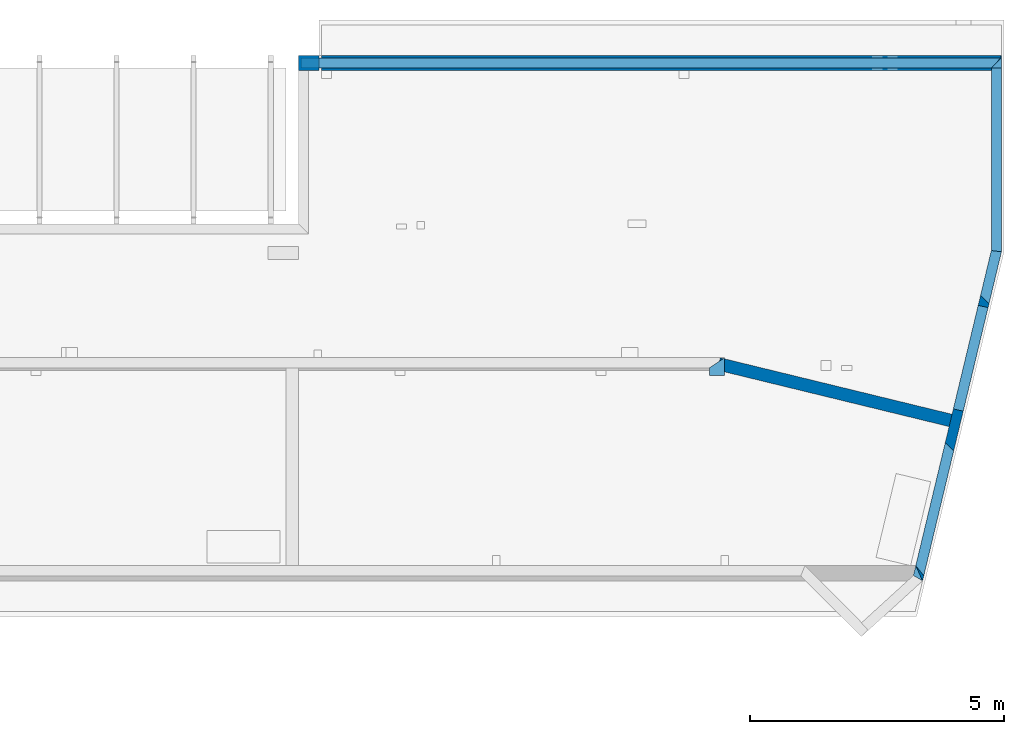
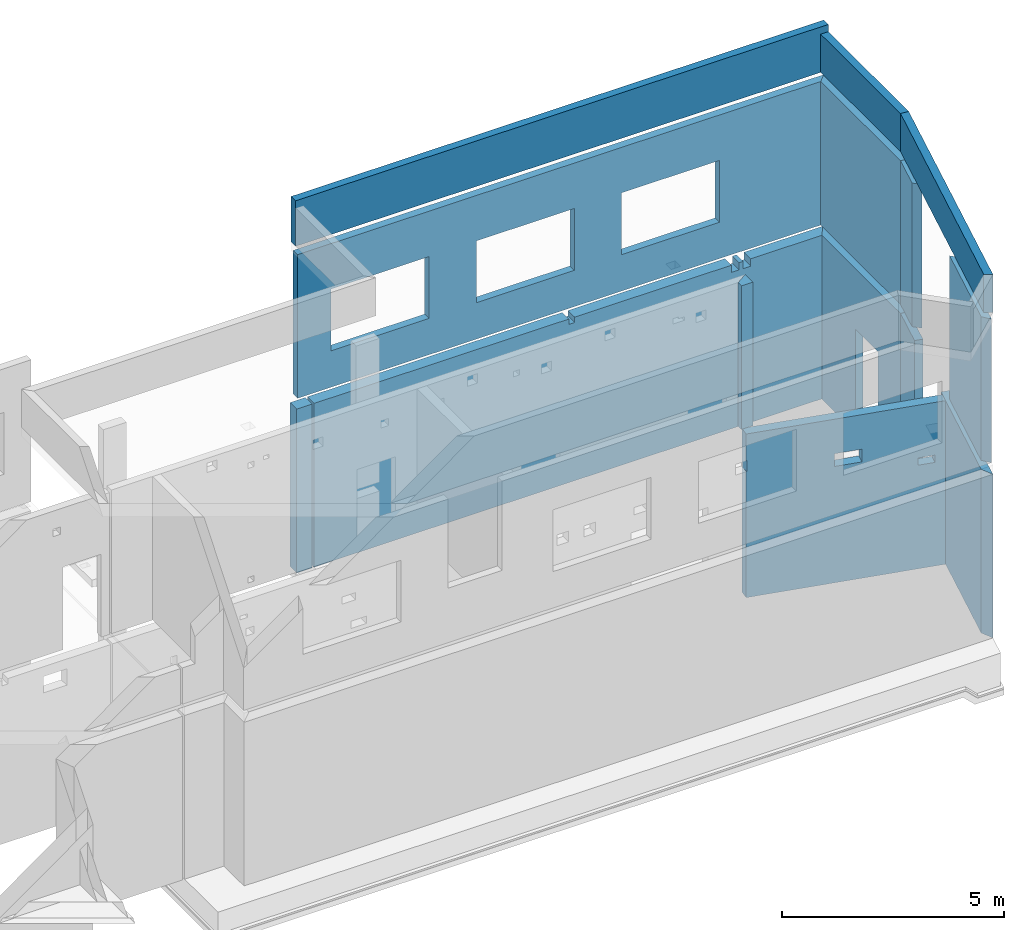
# One storey, part 4 of 7: 12 walls, 14 openings.
"""IFC2X3 building model written with IfcOpenShell, lengths in millimetres."""

from ifc_helpers import new_model, entity, si_unit, converted_unit, derived_unit, money_unit, direction, frame, frame_2d, origin_with_axes, place, context, subcontext, project, spatial, polyline, rectangle, outline, extrude, faceted_brep, material, layer, layer_set, layer_usage, type_object, element, save


model = new_model("IFC2X3")

# Units and contexts
model_context = context("Model", 3, precision=1e-05, world=origin_with_axes(), true_north=direction((0.0, 1.0)))
body_context = subcontext(model_context, "Body", "Model", "MODEL_VIEW", scale=1.0)
ifc_project = project(units=[si_unit("LENGTHUNIT", "METRE", prefix="MILLI"), si_unit("AREAUNIT", "SQUARE_METRE"), si_unit("VOLUMEUNIT", "CUBIC_METRE"), si_unit("ABSORBEDDOSEUNIT", "GRAY"), si_unit("AMOUNTOFSUBSTANCEUNIT", "MOLE"), si_unit("DOSEEQUIVALENTUNIT", "SIEVERT"), si_unit("ELECTRICCAPACITANCEUNIT", "FARAD"), si_unit("ELECTRICCHARGEUNIT", "COULOMB"), si_unit("ELECTRICCONDUCTANCEUNIT", "SIEMENS"), si_unit("ELECTRICCURRENTUNIT", "AMPERE"), si_unit("ELECTRICRESISTANCEUNIT", "OHM"), si_unit("ELECTRICVOLTAGEUNIT", "VOLT"), si_unit("ENERGYUNIT", "JOULE"), si_unit("FORCEUNIT", "NEWTON"), si_unit("FREQUENCYUNIT", "HERTZ"), si_unit("ILLUMINANCEUNIT", "LUX"), si_unit("INDUCTANCEUNIT", "HENRY"), si_unit("LUMINOUSFLUXUNIT", "LUMEN"), si_unit("LUMINOUSINTENSITYUNIT", "CANDELA"), si_unit("MAGNETICFLUXDENSITYUNIT", "TESLA"), si_unit("MAGNETICFLUXUNIT", "WEBER"), si_unit("MASSUNIT", "GRAM"), converted_unit("PLANEANGLEUNIT", "degree", entity("IfcReal", 0.0174532925199433), si_unit("PLANEANGLEUNIT", "RADIAN"), dimensions=[0, 0, 0, 0, 0, 0, 0]), si_unit("POWERUNIT", "WATT"), si_unit("PRESSUREUNIT", "PASCAL"), si_unit("RADIOACTIVITYUNIT", "BECQUEREL"), si_unit("SOLIDANGLEUNIT", "STERADIAN"), si_unit("THERMODYNAMICTEMPERATUREUNIT", "KELVIN"), si_unit("TIMEUNIT", "SECOND"), derived_unit("ACCELERATIONUNIT", [(si_unit("LENGTHUNIT", "METRE", prefix="MILLI"), 1), (si_unit("TIMEUNIT", "SECOND"), -2)]), derived_unit("ANGULARVELOCITYUNIT", [(converted_unit("PLANEANGLEUNIT", "degree", entity("IfcReal", 0.0174532925199433), si_unit("PLANEANGLEUNIT", "RADIAN"), dimensions=[0, 0, 0, 0, 0, 0, 0]), 1), (si_unit("TIMEUNIT", "SECOND"), -1)]), derived_unit("CURVATUREUNIT", [(converted_unit("PLANEANGLEUNIT", "degree", entity("IfcReal", 0.0174532925199433), si_unit("PLANEANGLEUNIT", "RADIAN"), dimensions=[0, 0, 0, 0, 0, 0, 0]), 1), (si_unit("LENGTHUNIT", "METRE", prefix="MILLI"), -1)]), derived_unit("DYNAMICVISCOSITYUNIT", [(si_unit("PRESSUREUNIT", "PASCAL"), 1), (si_unit("TIMEUNIT", "SECOND"), 1)]), derived_unit("HEATFLUXDENSITYUNIT", [(si_unit("POWERUNIT", "WATT"), 1), (si_unit("LENGTHUNIT", "METRE", prefix="MILLI"), -2)]), derived_unit("HEATINGVALUEUNIT", [(si_unit("ENERGYUNIT", "JOULE"), 1), (si_unit("MASSUNIT", "GRAM"), -1)]), derived_unit("INTEGERCOUNTRATEUNIT", [(si_unit("TIMEUNIT", "SECOND"), -1)]), derived_unit("IONCONCENTRATIONUNIT", [(si_unit("MASSUNIT", "GRAM"), 1), (si_unit("VOLUMEUNIT", "CUBIC_METRE"), -1)]), derived_unit("ISOTHERMALMOISTURECAPACITYUNIT", [(si_unit("VOLUMEUNIT", "CUBIC_METRE"), 1), (si_unit("MASSUNIT", "GRAM"), -1)]), derived_unit("KINEMATICVISCOSITYUNIT", [(si_unit("AREAUNIT", "SQUARE_METRE"), 1), (si_unit("TIMEUNIT", "SECOND"), -1)]), derived_unit("LINEARFORCEUNIT", [(si_unit("FORCEUNIT", "NEWTON"), 1), (si_unit("LENGTHUNIT", "METRE", prefix="MILLI"), -1)]), derived_unit("LINEARMOMENTUNIT", [(si_unit("FORCEUNIT", "NEWTON"), 1), (si_unit("LENGTHUNIT", "METRE", prefix="MILLI"), -1)]), derived_unit("LINEARSTIFFNESSUNIT", [(si_unit("FORCEUNIT", "NEWTON"), 1), (si_unit("LENGTHUNIT", "METRE", prefix="MILLI"), -1)]), derived_unit("LINEARVELOCITYUNIT", [(si_unit("LENGTHUNIT", "METRE", prefix="MILLI"), 1), (si_unit("TIMEUNIT", "SECOND"), -1)]), derived_unit("LUMINOUSINTENSITYDISTRIBUTIONUNIT", [(si_unit("LUMINOUSINTENSITYUNIT", "CANDELA"), 1), (si_unit("LUMINOUSFLUXUNIT", "LUMEN"), -1)]), derived_unit("MASSDENSITYUNIT", [(si_unit("MASSUNIT", "GRAM"), 1), (si_unit("VOLUMEUNIT", "CUBIC_METRE"), -1)]), derived_unit("MASSFLOWRATEUNIT", [(si_unit("MASSUNIT", "GRAM"), 1), (si_unit("TIMEUNIT", "SECOND"), -1)]), derived_unit("MASSPERLENGTHUNIT", [(si_unit("MASSUNIT", "GRAM"), 1), (si_unit("LENGTHUNIT", "METRE", prefix="MILLI"), -1)]), derived_unit("MODULUSOFELASTICITYUNIT", [(si_unit("FORCEUNIT", "NEWTON"), 1), (si_unit("AREAUNIT", "SQUARE_METRE"), -1)]), derived_unit("MODULUSOFLINEARSUBGRADEREACTIONUNIT", [(si_unit("FORCEUNIT", "NEWTON"), 1), (si_unit("LENGTHUNIT", "METRE", prefix="MILLI"), -2)]), derived_unit("MODULUSOFROTATIONALSUBGRADEREACTIONUNIT", [(si_unit("FORCEUNIT", "NEWTON"), 1), (si_unit("LENGTHUNIT", "METRE", prefix="MILLI"), 1)]), derived_unit("MODULUSOFSUBGRADEREACTIONUNIT", [(si_unit("FORCEUNIT", "NEWTON"), 1), (si_unit("VOLUMEUNIT", "CUBIC_METRE"), -1)]), derived_unit("MOISTUREDIFFUSIVITYUNIT", [(si_unit("VOLUMEUNIT", "CUBIC_METRE"), 1), (si_unit("TIMEUNIT", "SECOND"), -1)]), derived_unit("MOLECULARWEIGHTUNIT", [(si_unit("MASSUNIT", "GRAM"), 1), (si_unit("AMOUNTOFSUBSTANCEUNIT", "MOLE"), -1)]), derived_unit("PLANARFORCEUNIT", [(si_unit("FORCEUNIT", "NEWTON"), 1), (si_unit("LENGTHUNIT", "METRE", prefix="MILLI"), -2)]), derived_unit("ROTATIONALFREQUENCYUNIT", [(si_unit("TIMEUNIT", "SECOND"), -1)]), derived_unit("ROTATIONALMASSUNIT", [(si_unit("MASSUNIT", "GRAM"), 1), (si_unit("LENGTHUNIT", "METRE", prefix="MILLI"), 2)]), derived_unit("ROTATIONALSTIFFNESSUNIT", [(si_unit("FORCEUNIT", "NEWTON"), 1), (si_unit("LENGTHUNIT", "METRE", prefix="MILLI"), 1), (converted_unit("PLANEANGLEUNIT", "degree", entity("IfcReal", 0.0174532925199433), si_unit("PLANEANGLEUNIT", "RADIAN"), dimensions=[0, 0, 0, 0, 0, 0, 0]), -1)]), derived_unit("SECTIONAREAINTEGRALUNIT", [(si_unit("LENGTHUNIT", "METRE", prefix="MILLI"), 5)]), derived_unit("SECTIONMODULUSUNIT", [(si_unit("LENGTHUNIT", "METRE", prefix="MILLI"), 3)]), derived_unit("SHEARMODULUSUNIT", [(si_unit("FORCEUNIT", "NEWTON"), 1), (si_unit("AREAUNIT", "SQUARE_METRE"), -1)]), derived_unit("SOUNDPOWERUNIT", [(si_unit("ENERGYUNIT", "JOULE"), 1), (si_unit("TIMEUNIT", "SECOND"), -1)]), derived_unit("SPECIFICHEATCAPACITYUNIT", [(si_unit("FORCEUNIT", "NEWTON"), 1), (si_unit("MASSUNIT", "GRAM"), -1), (si_unit("THERMODYNAMICTEMPERATUREUNIT", "KELVIN"), -1)]), derived_unit("TEMPERATUREGRADIENTUNIT", [(si_unit("THERMODYNAMICTEMPERATUREUNIT", "KELVIN"), 1), (si_unit("LENGTHUNIT", "METRE", prefix="MILLI"), -1)]), derived_unit("THERMALADMITTANCEUNIT", [(si_unit("POWERUNIT", "WATT"), 1), (si_unit("AREAUNIT", "SQUARE_METRE"), -1), (si_unit("THERMODYNAMICTEMPERATUREUNIT", "KELVIN"), -1)]), derived_unit("THERMALCONDUCTANCEUNIT", [(si_unit("POWERUNIT", "WATT"), 1), (si_unit("LENGTHUNIT", "METRE", prefix="MILLI"), -1), (si_unit("THERMODYNAMICTEMPERATUREUNIT", "KELVIN"), -1)]), derived_unit("THERMALEXPANSIONCOEFFICIENTUNIT", [(si_unit("THERMODYNAMICTEMPERATUREUNIT", "KELVIN"), -1)]), derived_unit("THERMALRESISTANCEUNIT", [(si_unit("AREAUNIT", "SQUARE_METRE"), 1), (si_unit("POWERUNIT", "WATT"), -1)]), derived_unit("THERMALTRANSMITTANCEUNIT", [(si_unit("POWERUNIT", "WATT"), 1), (si_unit("AREAUNIT", "SQUARE_METRE"), -1), (si_unit("THERMODYNAMICTEMPERATUREUNIT", "KELVIN"), -1)]), derived_unit("TORQUEUNIT", [(si_unit("FORCEUNIT", "NEWTON"), 1), (si_unit("LENGTHUNIT", "METRE", prefix="MILLI"), 1)]), derived_unit("VAPORPERMEABILITYUNIT", [(si_unit("MASSUNIT", "GRAM"), 1), (si_unit("TIMEUNIT", "SECOND"), -1)]), derived_unit("VOLUMETRICFLOWRATEUNIT", [(si_unit("VOLUMEUNIT", "CUBIC_METRE"), 1), (si_unit("TIMEUNIT", "SECOND"), -1)]), derived_unit("WARPINGCONSTANTUNIT", [(si_unit("LENGTHUNIT", "METRE", prefix="MILLI"), 6)]), derived_unit("WARPINGMOMENTUNIT", [(si_unit("FORCEUNIT", "NEWTON"), 1), (si_unit("LENGTHUNIT", "METRE", prefix="MILLI"), 2)]), money_unit("USD")], contexts=[model_context])

# Site, building, storey
site_placement = place(None, origin_with_axes())
site = spatial("IfcSite", under=ifc_project, at=site_placement, CompositionType="ELEMENT")
building_placement = place(site_placement, origin_with_axes())
building = spatial("IfcBuilding", under=site, at=building_placement, Name="1", CompositionType="ELEMENT")
storey_placement = place(building_placement, frame((0.0, 0.0, -4900.0), z_axis=(0.0, 0.0, 1.0), x_axis=(1.0, 0.0, 0.0)))
storey = spatial("IfcBuildingStorey", under=building, at=storey_placement, Name="-2", CompositionType="ELEMENT", Elevation=-4900.0)

# Wall, opening
ifc_material = material()
ifc_layer_1 = layer(ifc_material, 200.0, ventilated=False)
ifc_layer_set_1 = layer_set([ifc_layer_1])
ifc_layer_usage_1 = layer_usage(ifc_layer_set_1, "AXIS2", "POSITIVE", 0.0)
wall_type = type_object("IfcWallType", PredefinedType="NOTDEFINED")
wall_1_placement = place(storey_placement, frame((28458.86, -300.0, 0.0), z_axis=(0.0, 0.0, 1.0), x_axis=(0.23316545, 0.97243708, 0.0)))
wall_1 = element("IfcWallStandardCase", 1, at=wall_1_placement, inside=storey, type_object=wall_type, material=ifc_layer_usage_1, context=body_context, shape_type="SweptSolid", body=[
    extrude(outline(polyline([(6650.31, 200.0), (260.55, 200.0), (0.0, 0.0), (6673.95, 0.0), (6650.31, 200.0)])), origin_with_axes(), (0.0, 0.0, 1.0), 4500.0),
])
opening_1_placement = place(wall_1_placement, frame((3440.39, 0.0, 550.0), z_axis=(0.0, 0.0, 1.0), x_axis=(1.0, 0.0, 0.0)))
element("IfcOpeningElement", 2, at=opening_1_placement, cuts=wall_1, ObjectType="Opening", context=body_context, shape_type="SweptSolid", body=[
    extrude(rectangle(XDim=3950.0, YDim=2100.0, at=frame_2d((-1050.0, 1975.0), x_axis=(0.0, -1.0))), frame((0.0, 0.0, 0.0), z_axis=(0.0, 1.0, 0.0), x_axis=(-1.0, 0.0, 0.0)), (0.0, 0.0, 1.0), 200.0),
])

wall_2_placement = place(storey_placement, frame((30015.0, 6190.0, 0.0), z_axis=(0.0, 0.0, 1.0), x_axis=(0.0, 1.0, 0.0)))
wall_2 = element("IfcWallStandardCase", 3, at=wall_2_placement, inside=storey, type_object=wall_type, material=ifc_layer_usage_1, context=body_context, shape_type="SweptSolid", body=[
    extrude(outline(polyline([(3570.0, 200.0), (23.64, 200.0), (0.0, 0.0), (3870.0, 0.0), (3570.0, 200.0)])), origin_with_axes(), (0.0, 0.0, 1.0), 4500.0),
])
opening_2_placement = place(wall_2_placement, frame((1030.0, 0.0, 550.0), z_axis=(0.0, 0.0, 1.0), x_axis=(1.0, 0.0, 0.0)))
element("IfcOpeningElement", 4, at=opening_2_placement, cuts=wall_2, ObjectType="Opening", context=body_context, shape_type="SweptSolid", body=[
    extrude(rectangle(XDim=2280.0, YDim=1020.0, at=frame_2d((-510.0, 1140.0), x_axis=(0.0, -1.0))), frame((0.0, 0.0, 0.0), z_axis=(0.0, 1.0, 0.0), x_axis=(-1.0, 0.0, 0.0)), (0.0, 0.0, 1.0), 200.0),
])

# Wall
ifc_layer_2 = layer(ifc_material, 300.0, ventilated=False)
ifc_layer_set_2 = layer_set([ifc_layer_2])
ifc_layer_usage_2 = layer_usage(ifc_layer_set_2, "AXIS2", "POSITIVE", 0.0)
wall_3_placement = place(storey_placement, frame((16555.0, 10060.0, 0.0), z_axis=(0.0, 0.0, 1.0), x_axis=(-1.0, 0.0, 0.0)))
element("IfcWallStandardCase", 5, at=wall_3_placement, inside=storey, type_object=wall_type, material=ifc_layer_usage_2, context=body_context, shape_type="SweptSolid", body=[
    extrude(rectangle(XDim=400.0, YDim=300.0, at=frame_2d((200.0, 150.0), x_axis=(1.0, 0.0))), origin_with_axes(), (0.0, 0.0, 1.0), 4500.0),
])

# Wall, openings
wall_4_placement = place(storey_placement, frame((30015.0, 10060.0, 0.0), z_axis=(0.0, 0.0, 1.0), x_axis=(-1.0, 0.0, 0.0)))
wall_4 = element("IfcWallStandardCase", 6, at=wall_4_placement, inside=storey, type_object=wall_type, material=ifc_layer_usage_2, context=body_context, shape_type="SweptSolid", body=[
    extrude(outline(polyline([(200.0, 300.0), (0.0, 0.0), (13410.0, 0.0), (13410.0, 300.0), (200.0, 300.0)])), origin_with_axes(), (0.0, 0.0, 1.0), 4500.0),
])
opening_3_placement = place(wall_4_placement, frame((6630.0, 0.0, 4350.0), z_axis=(0.0, 0.0, 1.0), x_axis=(1.0, 0.0, 0.0)))
element("IfcOpeningElement", 7, at=opening_3_placement, cuts=wall_4, ObjectType="Opening", context=body_context, shape_type="SweptSolid", body=[
    extrude(rectangle(XDim=150.0, YDim=150.0, at=frame_2d((-75.0, 75.0), x_axis=(0.0, -1.0))), frame((0.0, 0.0, 0.0), z_axis=(0.0, 1.0, 0.0), x_axis=(-1.0, 0.0, 0.0)), (0.0, 0.0, 1.0), 300.0),
])
opening_4_placement = place(wall_4_placement, frame((2350.0, 0.0, 4300.0), z_axis=(0.0, 0.0, 1.0), x_axis=(1.0, 0.0, 0.0)))
element("IfcOpeningElement", 8, at=opening_4_placement, cuts=wall_4, ObjectType="Opening", context=body_context, shape_type="SweptSolid", body=[
    extrude(rectangle(XDim=200.0, YDim=200.0, at=frame_2d((-100.0, 100.0), x_axis=(0.0, -1.0))), frame((0.0, 0.0, 0.0), z_axis=(0.0, 1.0, 0.0), x_axis=(-1.0, 0.0, 0.0)), (0.0, 0.0, 1.0), 300.0),
])
opening_5_placement = place(wall_4_placement, frame((2050.0, 0.0, 4300.0), z_axis=(0.0, 0.0, 1.0), x_axis=(1.0, 0.0, 0.0)))
element("IfcOpeningElement", 9, at=opening_5_placement, cuts=wall_4, ObjectType="Opening", context=body_context, shape_type="SweptSolid", body=[
    extrude(rectangle(XDim=200.0, YDim=200.0, at=frame_2d((-100.0, 100.0), x_axis=(0.0, -1.0))), frame((0.0, 0.0, 0.0), z_axis=(0.0, 1.0, 0.0), x_axis=(-1.0, 0.0, 0.0)), (0.0, 0.0, 1.0), 300.0),
])

ifc_layer_3 = layer(ifc_material, 250.0, ventilated=False)
ifc_layer_set_3 = layer_set([ifc_layer_3])
ifc_layer_usage_3 = layer_usage(ifc_layer_set_3, "AXIS2", "POSITIVE", 0.0)
wall_5_placement = place(storey_placement, frame((24434.99, 3850.0, 0.0), z_axis=(0.0, 0.0, 1.0), x_axis=(0.97159196, -0.23666233, 0.0)))
wall_5 = element("IfcWallStandardCase", 10, at=wall_5_placement, inside=storey, type_object=wall_type, material=ifc_layer_usage_3, context=body_context, shape_type="SweptSolid", body=[
    extrude(outline(polyline([(4679.73, 250.0), (-30.01, 250.0), (0.0, 0.0), (4680.63, 0.0), (4679.73, 250.0)])), origin_with_axes(), (0.0, 0.0, 1.0), 4500.0),
])
opening_6_placement = place(wall_5_placement, frame((2070.61, 0.0, 3200.0), z_axis=(0.0, 0.0, 1.0), x_axis=(1.0, 0.0, 0.0)))
element("IfcOpeningElement", 11, at=opening_6_placement, cuts=wall_5, ObjectType="Opening", context=body_context, shape_type="SweptSolid", body=[
    extrude(rectangle(XDim=350.0, YDim=650.0, at=frame_2d((-325.0, 175.0), x_axis=(0.0, -1.0))), frame((0.0, 0.0, 0.0), z_axis=(0.0, 1.0, 0.0), x_axis=(-1.0, 0.0, 0.0)), (0.0, 0.0, 1.0), 250.0),
])
opening_7_placement = place(wall_5_placement, frame((4030.63, 0.0, 2850.0), z_axis=(0.0, 0.0, 1.0), x_axis=(1.0, 0.0, 0.0)))
element("IfcOpeningElement", 12, at=opening_7_placement, cuts=wall_5, ObjectType="Opening", context=body_context, shape_type="SweptSolid", body=[
    extrude(rectangle(XDim=200.0, YDim=400.0, at=frame_2d((-200.0, 100.0), x_axis=(0.0, -1.0))), frame((0.0, 0.0, 0.0), z_axis=(0.0, 1.0, 0.0), x_axis=(-1.0, 0.0, 0.0)), (0.0, 0.0, 1.0), 250.0),
])
opening_8_placement = place(wall_5_placement, frame((-20.01, 0.0, 3465.0), z_axis=(0.0, 0.0, 1.0), x_axis=(1.0, 0.0, 0.0)))
element("IfcOpeningElement", 13, at=opening_8_placement, cuts=wall_5, ObjectType="Recess", context=body_context, shape_type="Brep", body=[
    faceted_brep([(20.01, 0.0, 0.0), (40.6, 0.0, 0.0), (40.6, 0.0, 300.0), (20.01, 0.0, 300.0), (0.0, 166.69, 0.0), (0.0, 166.69, 300.0)], [[[0, 1, 2, 3]], [[4, 0, 3, 5]], [[4, 1, 0]], [[5, 2, 1, 4]], [[3, 2, 5]]]),
])

wall_6_placement = place(storey_placement, frame((30015.0, 10010.0, 4750.0), z_axis=(0.0, 0.0, 1.0), x_axis=(-1.0, 0.0, 0.0)))
wall_6 = element("IfcWallStandardCase", 14, at=wall_6_placement, inside=storey, type_object=wall_type, material=ifc_layer_usage_1, context=body_context, shape_type="SweptSolid", body=[
    extrude(outline(polyline([(200.0, 200.0), (0.0, 0.0), (13810.0, 0.0), (13810.0, 200.0), (200.0, 200.0)])), origin_with_axes(), (0.0, 0.0, 1.0), 3950.0),
])
opening_9_placement = place(wall_6_placement, frame((10390.0, 0.0, 1000.0), z_axis=(0.0, 0.0, 1.0), x_axis=(1.0, 0.0, 0.0)))
element("IfcOpeningElement", 15, at=opening_9_placement, cuts=wall_6, ObjectType="Opening", context=body_context, shape_type="SweptSolid", body=[
    extrude(rectangle(XDim=1700.0, YDim=2550.0, at=frame_2d((-1275.0, 850.0), x_axis=(0.0, -1.0))), frame((0.0, 0.0, 0.0), z_axis=(0.0, 1.0, 0.0), x_axis=(-1.0, 0.0, 0.0)), (0.0, 0.0, 1.0), 200.0),
])
opening_10_placement = place(wall_6_placement, frame((6610.0, 0.0, 1000.0), z_axis=(0.0, 0.0, 1.0), x_axis=(1.0, 0.0, 0.0)))
element("IfcOpeningElement", 16, at=opening_10_placement, cuts=wall_6, ObjectType="Opening", context=body_context, shape_type="SweptSolid", body=[
    extrude(rectangle(XDim=1700.0, YDim=2550.0, at=frame_2d((-1275.0, 850.0), x_axis=(0.0, -1.0))), frame((0.0, 0.0, 0.0), z_axis=(0.0, 1.0, 0.0), x_axis=(-1.0, 0.0, 0.0)), (0.0, 0.0, 1.0), 200.0),
])
opening_11_placement = place(wall_6_placement, frame((2830.0, 0.0, 1000.0), z_axis=(0.0, 0.0, 1.0), x_axis=(1.0, 0.0, 0.0)))
element("IfcOpeningElement", 17, at=opening_11_placement, cuts=wall_6, ObjectType="Opening", context=body_context, shape_type="SweptSolid", body=[
    extrude(rectangle(XDim=1700.0, YDim=2550.0, at=frame_2d((-1275.0, 850.0), x_axis=(0.0, -1.0))), frame((0.0, 0.0, 0.0), z_axis=(0.0, 1.0, 0.0), x_axis=(-1.0, 0.0, 0.0)), (0.0, 0.0, 1.0), 200.0),
])

# Wall
wall_7_placement = place(storey_placement, frame((30015.0, 10010.0, 4750.0), z_axis=(0.0, 0.0, 1.0), x_axis=(0.0, -1.0, 0.0)))
element("IfcWallStandardCase", 18, at=wall_7_placement, inside=storey, type_object=wall_type, material=ifc_layer_usage_1, context=body_context, shape_type="SweptSolid", body=[
    extrude(outline(polyline([(3820.0, 0.0), (0.0, 0.0), (200.0, -200.0), (3796.36, -200.0), (3820.0, 0.0)])), origin_with_axes(), (0.0, 0.0, 1.0), 3950.0),
])

# Wall, openings
wall_8_placement = place(storey_placement, frame((30015.0, 6190.0, 4750.0), z_axis=(0.0, 0.0, 1.0), x_axis=(-0.23316545, -0.97243708, 0.0)))
wall_8 = element("IfcWallStandardCase", 19, at=wall_8_placement, inside=storey, type_object=wall_type, material=ifc_layer_usage_1, context=body_context, shape_type="SweptSolid", body=[
    extrude(outline(polyline([(6571.12, 0.0), (0.0, 0.0), (23.64, -200.0), (6413.41, -200.0), (6571.12, 0.0)])), origin_with_axes(), (0.0, 0.0, 1.0), 3950.0),
])
opening_12_placement = place(wall_8_placement, frame((1058.41, -200.0, 0.0), z_axis=(0.0, 0.0, 1.0), x_axis=(1.0, 0.0, 0.0)))
element("IfcOpeningElement", 20, at=opening_12_placement, cuts=wall_8, ObjectType="Opening", context=body_context, shape_type="SweptSolid", body=[
    extrude(rectangle(XDim=3950.0, YDim=2855.0, at=frame_2d((-1427.5, 1975.0), x_axis=(0.0, -1.0))), frame((0.0, 0.0, 0.0), z_axis=(0.0, 1.0, 0.0), x_axis=(-1.0, 0.0, 0.0)), (0.0, 0.0, 1.0), 200.0),
])
opening_13_placement = place(wall_8_placement, frame((3766.0, -200.0, 0.0), z_axis=(0.0, 0.0, 1.0), x_axis=(1.0, 0.0, 0.0)))
element("IfcOpeningElement", 21, at=opening_13_placement, cuts=wall_8, ObjectType="Opening", context=body_context, shape_type="Brep", body=[
    faceted_brep([(125.0, 200.0, 3950.0), (0.0, 0.0, 3950.0), (147.41, 0.0, 3950.0), (272.41, 200.0, 3950.0), (0.0, 0.0, 0.0), (147.41, 0.0, 0.0), (125.0, 200.0, 0.0), (272.41, 200.0, 0.0)], [[[0, 1, 2, 3]], [[1, 4, 5, 2]], [[6, 0, 3, 7]], [[4, 6, 7, 5]], [[5, 7, 3, 2]], [[1, 0, 6, 4]]]),
])
opening_14_placement = place(wall_8_placement, frame((933.38, -200.0, 0.0), z_axis=(0.0, 0.0, 1.0), x_axis=(1.0, 0.0, 0.0)))
element("IfcOpeningElement", 22, at=opening_14_placement, cuts=wall_8, ObjectType="Opening", context=body_context, shape_type="Brep", body=[
    faceted_brep([(125.0, 200.0, 3950.0), (0.0, 0.0, 3950.0), (147.41, 0.0, 3950.0), (272.41, 200.0, 3950.0), (0.0, 0.0, 0.0), (147.41, 0.0, 0.0), (125.0, 200.0, 0.0), (272.41, 200.0, 0.0)], [[[0, 1, 2, 3]], [[1, 4, 5, 2]], [[6, 0, 3, 7]], [[4, 6, 7, 5]], [[5, 7, 3, 2]], [[1, 0, 6, 4]]]),
])

# Walls
wall_9_placement = place(storey_placement, frame((24555.0, 3750.0, 4750.0), z_axis=(0.0, 0.0, 1.0), x_axis=(0.0, 1.0, 0.0)))
element("IfcWallStandardCase", 23, at=wall_9_placement, inside=storey, type_object=wall_type, material=ifc_layer_usage_2, context=body_context, shape_type="SweptSolid", body=[
    extrude(outline(polyline([(150.0, 300.0), (0.0, 300.0), (0.0, 0.0), (350.0, 0.0), (150.0, 300.0)])), origin_with_axes(), (0.0, 0.0, 1.0), 3950.0),
])
wall_10_placement = place(storey_placement, frame((16155.0, 10010.0, 8950.0), z_axis=(0.0, 0.0, 1.0), x_axis=(1.0, 0.0, 0.0)))
element("IfcWallStandardCase", 24, at=wall_10_placement, inside=storey, type_object=wall_type, material=ifc_layer_usage_1, context=body_context, shape_type="SweptSolid", body=[
    extrude(rectangle(XDim=13860.0, YDim=200.0, at=frame_2d((6930.0, -100.0), x_axis=(1.0, 0.0))), origin_with_axes(), (0.0, 0.0, 1.0), 1250.0),
])
wall_11_placement = place(storey_placement, frame((28458.86, -300.0, 8950.0), z_axis=(0.0, 0.0, 1.0), x_axis=(0.23316545, 0.97243708, 0.0)))
element("IfcWallStandardCase", 25, at=wall_11_placement, inside=storey, type_object=wall_type, material=ifc_layer_usage_1, context=body_context, shape_type="SweptSolid", body=[
    extrude(outline(polyline([(6650.31, 200.0), (61.42, 200.0), (0.0, 0.0), (6673.95, 0.0), (6650.31, 200.0)])), origin_with_axes(), (0.0, 0.0, 1.0), 1050.0),
])
wall_12_placement = place(storey_placement, frame((30015.0, 6190.0, 8950.0), z_axis=(0.0, 0.0, 1.0), x_axis=(0.0, 1.0, 0.0)))
element("IfcWallStandardCase", 26, at=wall_12_placement, inside=storey, type_object=wall_type, material=ifc_layer_usage_1, context=body_context, shape_type="SweptSolid", body=[
    extrude(outline(polyline([(23.64, 200.0), (0.0, 0.0), (3620.0, 0.0), (3620.0, 200.0), (23.64, 200.0)])), origin_with_axes(), (0.0, 0.0, 1.0), 1050.0),
])

save(model, "model.ifc")
